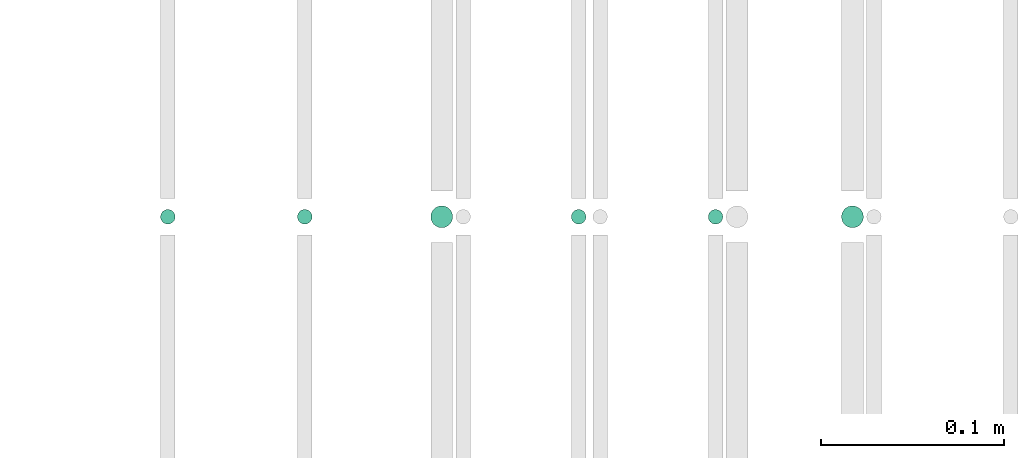
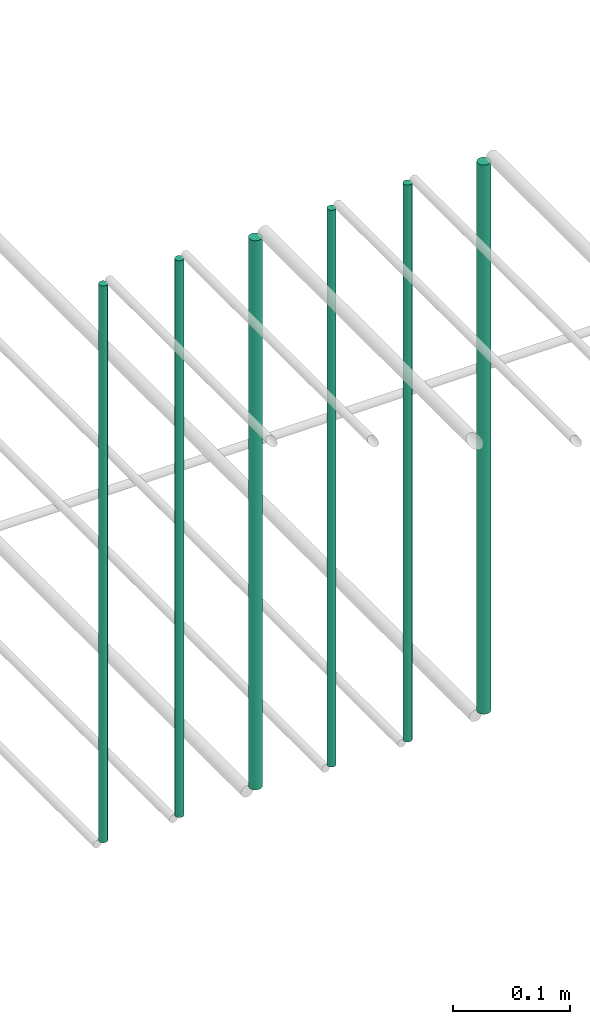
# One storey, part 138 of 331: 6 flow segments.
"""IFC2X3 building model written with IfcOpenShell, lengths in millimetres."""

from ifc_helpers import new_model, entity, si_unit, converted_unit, derived_unit, direction, frame, frame_2d, origin, origin_2d_with_axis, place, context, subcontext, project, spatial, circle, extrude, type_object, element, save


model = new_model("IFC2X3")

# Units and contexts
model_context = context("Model", 3, precision=0.01, world=origin(), true_north=direction((6.12303176911189e-17, 1.0)))
body_context = subcontext(model_context, "Body", "Model", "MODEL_VIEW")
ifc_project = project(units=[si_unit("LENGTHUNIT", "METRE", prefix="MILLI"), si_unit("AREAUNIT", "SQUARE_METRE"), si_unit("VOLUMEUNIT", "CUBIC_METRE"), converted_unit("PLANEANGLEUNIT", "DEGREE", entity("IfcRatioMeasure", 0.0174532925199433), si_unit("PLANEANGLEUNIT", "RADIAN"), dimensions=[0, 0, 0, 0, 0, 0, 0]), si_unit("MASSUNIT", "GRAM", prefix="KILO"), derived_unit("MASSDENSITYUNIT", [(si_unit("MASSUNIT", "GRAM", prefix="KILO"), 1), (si_unit("LENGTHUNIT", "METRE"), -3)]), derived_unit("MOMENTOFINERTIAUNIT", [(si_unit("LENGTHUNIT", "METRE"), 4)]), si_unit("TIMEUNIT", "SECOND"), si_unit("FREQUENCYUNIT", "HERTZ"), si_unit("THERMODYNAMICTEMPERATUREUNIT", "DEGREE_CELSIUS"), derived_unit("THERMALTRANSMITTANCEUNIT", [(si_unit("MASSUNIT", "GRAM", prefix="KILO"), 1), (si_unit("THERMODYNAMICTEMPERATUREUNIT", "KELVIN"), -1), (si_unit("TIMEUNIT", "SECOND"), -3)]), derived_unit("VOLUMETRICFLOWRATEUNIT", [(si_unit("LENGTHUNIT", "METRE"), 3), (si_unit("TIMEUNIT", "SECOND"), -1)]), derived_unit("MASSFLOWRATEUNIT", [(si_unit("MASSUNIT", "GRAM", prefix="KILO"), 1), (si_unit("TIMEUNIT", "SECOND"), -1)]), derived_unit("ROTATIONALFREQUENCYUNIT", [(si_unit("TIMEUNIT", "SECOND"), -1)]), si_unit("ELECTRICCURRENTUNIT", "AMPERE"), si_unit("ELECTRICVOLTAGEUNIT", "VOLT"), si_unit("POWERUNIT", "WATT"), si_unit("FORCEUNIT", "NEWTON", prefix="KILO"), si_unit("ILLUMINANCEUNIT", "LUX"), si_unit("LUMINOUSFLUXUNIT", "LUMEN"), si_unit("LUMINOUSINTENSITYUNIT", "CANDELA"), derived_unit("USERDEFINED", [(si_unit("MASSUNIT", "GRAM", prefix="KILO"), -1), (si_unit("LENGTHUNIT", "METRE"), -2), (si_unit("TIMEUNIT", "SECOND"), 3), (si_unit("LUMINOUSFLUXUNIT", "LUMEN"), 1)]), derived_unit("LINEARVELOCITYUNIT", [(si_unit("LENGTHUNIT", "METRE"), 1), (si_unit("TIMEUNIT", "SECOND"), -1)]), si_unit("PRESSUREUNIT", "PASCAL"), derived_unit("USERDEFINED", [(si_unit("LENGTHUNIT", "METRE"), -2), (si_unit("MASSUNIT", "GRAM", prefix="KILO"), 1), (si_unit("TIMEUNIT", "SECOND"), -2)]), derived_unit("LINEARFORCEUNIT", [(si_unit("MASSUNIT", "GRAM", prefix="KILO"), 1), (si_unit("LENGTHUNIT", "METRE"), 1), (si_unit("TIMEUNIT", "SECOND"), -2), (si_unit("LENGTHUNIT", "METRE"), -1)]), derived_unit("PLANARFORCEUNIT", [(si_unit("MASSUNIT", "GRAM", prefix="KILO"), 1), (si_unit("LENGTHUNIT", "METRE"), 1), (si_unit("TIMEUNIT", "SECOND"), -2), (si_unit("LENGTHUNIT", "METRE"), -2)])], contexts=[model_context])

# Site, building, storey
site_placement = place(None, frame((0.0, -0.00077364408347762, 0.0)))
site = spatial("IfcSite", under=ifc_project, at=site_placement, CompositionType="ELEMENT")
building_placement = place(site_placement, origin())
building = spatial("IfcBuilding", under=site, at=building_placement, CompositionType="ELEMENT")
storey_placement = place(building_placement, origin())
storey = spatial("IfcBuildingStorey", under=building, at=storey_placement, CompositionType="ELEMENT", Elevation=0.0)

# Flow segments
pipe_segment_type = type_object("IfcPipeSegmentType", PredefinedType="NOTDEFINED")
flow_segment_1_placement = place(storey_placement, frame((24903.7436346567, 5638.02529159143, 18460.0)))
element("IfcFlowSegment", 1, at=flow_segment_1_placement, inside=storey, type_object=pipe_segment_type, context=body_context, shape_type="SweptSolid", body=[
    extrude(circle(Radius=4.0, at=origin_2d_with_axis()), frame((5.59527223591499, 5.59527223591607, 0.0), z_axis=(0.0, 0.0, 1.0), x_axis=(-1.0, 0.0, 0.0)), (0.0, 0.0, 1.0), 580.000000000044),
])
flow_segment_2_placement = place(storey_placement, frame((24978.7436346567, 5638.02529159143, 18460.0)))
element("IfcFlowSegment", 2, at=flow_segment_2_placement, inside=storey, type_object=pipe_segment_type, context=body_context, shape_type="SweptSolid", body=[
    extrude(circle(Radius=4.0, at=origin_2d_with_axis()), frame((5.59527223591499, 5.59527223591607, 0.0), z_axis=(0.0, 0.0, 1.0), x_axis=(-1.0, 0.0, 0.0)), (0.0, 0.0, 1.0), 580.000000000007),
])
flow_segment_3_placement = place(storey_placement, frame((25051.7436346567, 5636.02529159143, 18464.0)))
element("IfcFlowSegment", 3, at=flow_segment_3_placement, inside=storey, type_object=pipe_segment_type, context=body_context, shape_type="SweptSolid", body=[
    extrude(circle(Radius=6.0, at=frame_2d((0.0, -1.08286712929839e-12), x_axis=(1.0, 0.0))), frame((7.59527223591454, 7.59527223591454, 0.0), z_axis=(0.0, 0.0, 1.0), x_axis=(-1.0, 0.0, 0.0)), (0.0, 0.0, 1.0), 572.000000000002),
])
flow_segment_4_placement = place(storey_placement, frame((25128.7436346567, 5638.02529159143, 18460.0)))
element("IfcFlowSegment", 4, at=flow_segment_4_placement, inside=storey, type_object=pipe_segment_type, context=body_context, shape_type="SweptSolid", body=[
    extrude(circle(Radius=4.0, at=origin_2d_with_axis()), frame((5.59527223591499, 5.59527223591607, 0.0), z_axis=(0.0, 0.0, 1.0), x_axis=(-1.0, 0.0, 0.0)), (0.0, 0.0, 1.0), 580.000000000041),
])
flow_segment_5_placement = place(storey_placement, frame((25203.7436346567, 5638.02559813429, 18460.0)))
element("IfcFlowSegment", 5, at=flow_segment_5_placement, inside=storey, type_object=pipe_segment_type, context=body_context, shape_type="SweptSolid", body=[
    extrude(circle(Radius=4.0, at=origin_2d_with_axis()), frame((5.59527223591499, 5.59527223591607, 0.0), z_axis=(0.0, 0.0, 1.0), x_axis=(-1.0, 0.0, 0.0)), (0.0, 0.0, 1.0), 580.0),
])
flow_segment_6_placement = place(storey_placement, frame((25276.7436346567, 5636.02529159144, 18464.0)))
element("IfcFlowSegment", 6, at=flow_segment_6_placement, inside=storey, type_object=pipe_segment_type, context=body_context, shape_type="SweptSolid", body=[
    extrude(circle(Radius=6.0, at=origin_2d_with_axis()), frame((7.59527223591454, 7.59527223591562, 0.0), z_axis=(0.0, 0.0, 1.0), x_axis=(-1.0, 0.0, 0.0)), (0.0, 0.0, 1.0), 572.000000000011),
])

save(model, "model.ifc")
